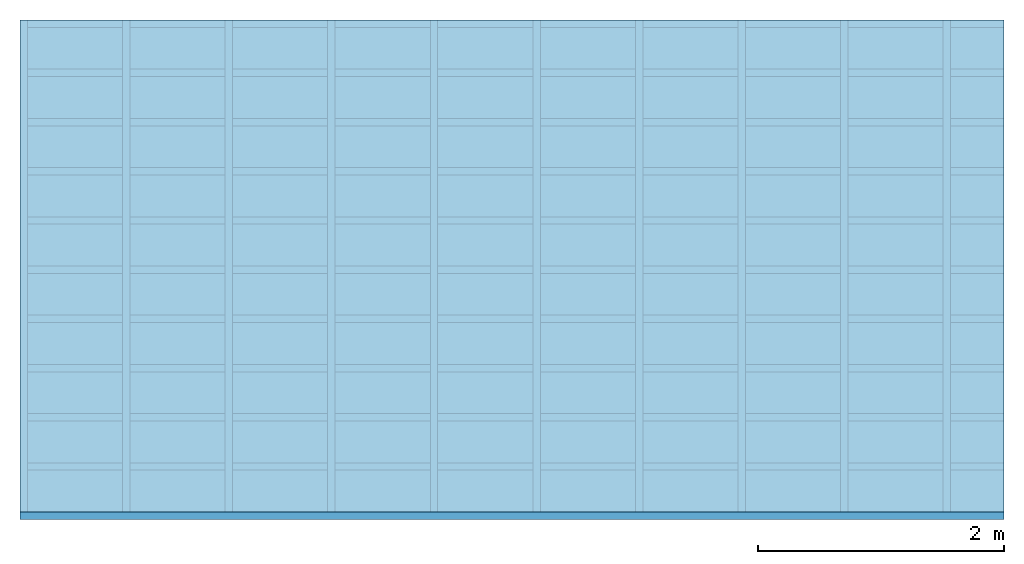
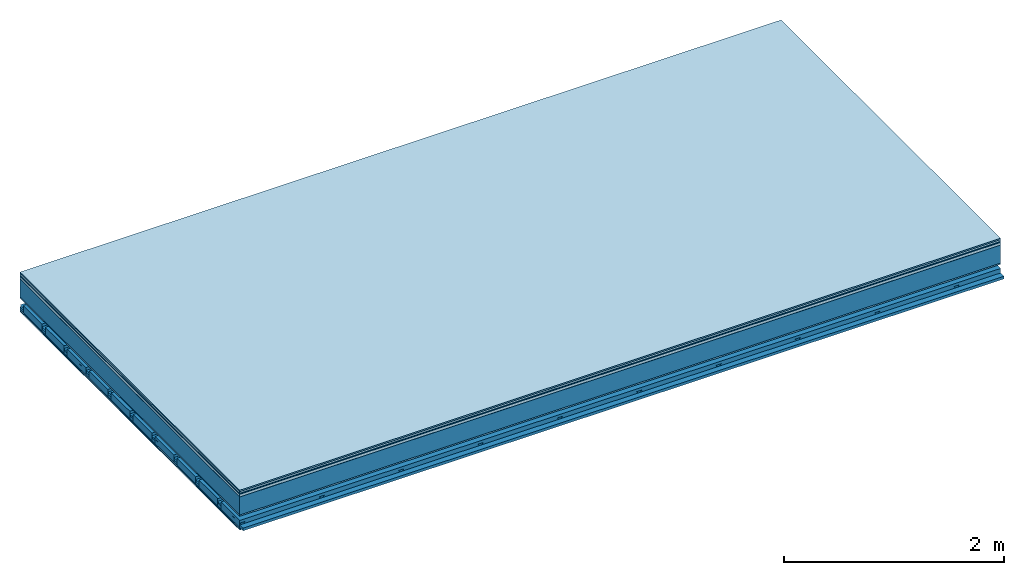
# One storey: 9 plates, 4 members, 1 element without a shape of its own.
"""IFC4 building model written with IfcOpenShell, lengths in metres."""

from ifc_helpers import new_model, si_unit, derived_unit, direction, frame, frame_2d, origin, origin_with_axes, place, context, project, spatial, polyline, rectangle, outline, extrude, material, layer, layer_set, type_object, element, aggregate, save


model = new_model("IFC4")

# Units and contexts
plan_context = context("Plan", 3, precision=1e-05, world=origin(), true_north=direction((0.0, 1.0)))
model_context = context("Model", 3, precision=1e-05, world=origin(), true_north=direction((0.0, 1.0)))
ifc_project = project(units=[si_unit("LENGTHUNIT", "METRE"), derived_unit("SOUNDPRESSUREUNIT", [(si_unit("PRESSUREUNIT", "PASCAL", prefix="MICRO"), 0)]), si_unit("ENERGYUNIT", "JOULE", prefix="MEGA"), si_unit("MASSUNIT", "GRAM", prefix="KILO"), derived_unit("THERMALTRANSMITTANCEUNIT", [(si_unit("POWERUNIT", "WATT"), 1), (si_unit("AREAUNIT", "SQUARE_METRE"), -1), (si_unit("THERMODYNAMICTEMPERATUREUNIT", "KELVIN"), -1)]), derived_unit("AREADENSITYUNIT", [(si_unit("MASSUNIT", "GRAM", prefix="KILO"), 1), (si_unit("AREAUNIT", "SQUARE_METRE"), -1)]), derived_unit("USERDEFINED", [(si_unit("ENERGYUNIT", "JOULE", prefix="MEGA"), 1), (si_unit("AREAUNIT", "SQUARE_METRE"), -1)])], contexts=[plan_context, model_context])

# Site, building, storey
site = spatial("IfcSite", under=ifc_project)
building_placement = place(None, origin())
building = spatial("IfcBuilding", under=site, at=building_placement)
storey_placement = place(building_placement, origin())
storey = spatial("IfcBuildingStorey", under=building, at=storey_placement)

# Slab, members, plates
ifc_material_1 = material(Category="11.013")
ifc_layer_1 = layer(ifc_material_1, 0.015, Name="Flooring")
ifc_material_2 = material(Category="03.007")
ifc_layer_2 = layer(ifc_material_2, 0.02, Name="On-material")
ifc_material_3 = material(Name="Wood fiber generic product", Category="10.009")
ifc_layer_3 = layer(ifc_material_3, 0.01, Name="Impact sound insulation")
ifc_material_4 = material(Name="with broken")
ifc_layer_4 = layer(ifc_material_4, 0.03, Name="on Supporting structure")
ifc_material_5 = material(Name="protection", Category="09.007")
ifc_layer_5 = layer(ifc_material_5, 0.0005, Name="Sub-floor")
ifc_material_6 = material(Name="no composite action")
ifc_layer_6 = layer(ifc_material_6, 0.0, Name="Bond")
ifc_layer_7 = layer(None, 0.2, Name="Supporting structure")
ifc_material_7 = material(Name="of the art")
ifc_layer_8 = layer(ifc_material_7, 0.0, Name="Bond")
ifc_layer_9 = layer(ifc_material_2, 0.015, Name="Lower layer 1")
ifc_layer_10 = layer(None, 0.095, Name="Coupling")
ifc_layer_11 = layer(None, 0.03, Name="Battens / profiles")
ifc_material_8 = material(Name="Plasterboard type A", Category="03.008")
ifc_layer_12 = layer(ifc_material_8, 0.0125, Name="Ceiling covering 1st layer")
ifc_layer_13 = layer(ifc_material_8, 0.0125, Name="Ceiling covering layer 2")
ifc_material_9 = material(Category="04.001")
ifc_layer_14 = layer(ifc_material_9, 0.003, Name="Surface / treatment")
ifc_layer_set = layer_set([ifc_layer_1, ifc_layer_2, ifc_layer_3, ifc_layer_4, ifc_layer_5, ifc_layer_6, ifc_layer_7, ifc_layer_8, ifc_layer_9, ifc_layer_10, ifc_layer_11, ifc_layer_12, ifc_layer_13, ifc_layer_14])
slab_type = type_object("IfcSlabType", Name="A2127", PredefinedType="NOTDEFINED", material=ifc_layer_set)
slab_placement = place(None, frame((0.0, 0.0, 0.0), z_axis=(0.0, 0.0, -1.0), x_axis=(1.0, 0.0, 0.0)))
slab = element("IfcSlab", 1, at=slab_placement, inside=storey, type_object=slab_type, material=ifc_layer_set, Name="Slab #1")
ifc_material_10 = material(Name="Solid timber panel")
member_1_placement = place(slab_placement, origin())
member_1 = element("IfcMember", 2, at=member_1_placement, material=ifc_material_10, Name="Supporting structure", context=plan_context, shape_type="SweptSolid", body=[
    extrude(rectangle(XDim=1.0, YDim=0.2, at=frame_2d((0.5, 0.1), x_axis=(1.0, 0.0))), frame((0.0, 4.0, 0.0755), z_axis=(0.0, -1.0, 0.0), x_axis=(1.0, 0.0, 0.0)), (0.0, 0.0, 1.0), 4.0),
    extrude(rectangle(XDim=1.0, YDim=0.2, at=frame_2d((0.5, 0.1), x_axis=(1.0, 0.0))), frame((1.0, 4.0, 0.0755), z_axis=(0.0, -1.0, 0.0), x_axis=(1.0, 0.0, 0.0)), (0.0, 0.0, 1.0), 4.0),
    extrude(rectangle(XDim=1.0, YDim=0.2, at=frame_2d((0.5, 0.1), x_axis=(1.0, 0.0))), frame((2.0, 4.0, 0.0755), z_axis=(0.0, -1.0, 0.0), x_axis=(1.0, 0.0, 0.0)), (0.0, 0.0, 1.0), 4.0),
    extrude(rectangle(XDim=1.0, YDim=0.2, at=frame_2d((0.5, 0.1), x_axis=(1.0, 0.0))), frame((3.0, 4.0, 0.0755), z_axis=(0.0, -1.0, 0.0), x_axis=(1.0, 0.0, 0.0)), (0.0, 0.0, 1.0), 4.0),
    extrude(rectangle(XDim=1.0, YDim=0.2, at=frame_2d((0.5, 0.1), x_axis=(1.0, 0.0))), frame((4.0, 4.0, 0.0755), z_axis=(0.0, -1.0, 0.0), x_axis=(1.0, 0.0, 0.0)), (0.0, 0.0, 1.0), 4.0),
    extrude(rectangle(XDim=1.0, YDim=0.2, at=frame_2d((0.5, 0.1), x_axis=(1.0, 0.0))), frame((5.0, 4.0, 0.0755), z_axis=(0.0, -1.0, 0.0), x_axis=(1.0, 0.0, 0.0)), (0.0, 0.0, 1.0), 4.0),
    extrude(rectangle(XDim=1.0, YDim=0.2, at=frame_2d((0.5, 0.1), x_axis=(1.0, 0.0))), frame((6.0, 4.0, 0.0755), z_axis=(0.0, -1.0, 0.0), x_axis=(1.0, 0.0, 0.0)), (0.0, 0.0, 1.0), 4.0),
    extrude(rectangle(XDim=1.0, YDim=0.2, at=frame_2d((0.5, 0.1), x_axis=(1.0, 0.0))), frame((7.0, 4.0, 0.0755), z_axis=(0.0, -1.0, 0.0), x_axis=(1.0, 0.0, 0.0)), (0.0, 0.0, 1.0), 4.0),
])
ifc_material_11 = material()
member_2_placement = place(slab_placement, origin())
member_2 = element("IfcMember", 3, at=member_2_placement, material=ifc_material_11, Name="Coupling", context=plan_context, shape_type="SweptSolid", body=[
    extrude(outline(polyline([(0.0, 0.0), (0.06, 0.0), (0.04, 0.02), (0.02, 0.02), (0.0, 0.0)])), frame((0.0, 4.0, 0.3655), z_axis=(0.0, -1.0, 0.0), x_axis=(1.0, 0.0, 0.0)), (0.0, 0.0, 1.0), 4.0),
    extrude(outline(polyline([(0.0, 0.0), (0.06, 0.0), (0.04, 0.02), (0.02, 0.02), (0.0, 0.0)])), frame((0.834, 4.0, 0.3655), z_axis=(0.0, -1.0, 0.0), x_axis=(1.0, 0.0, 0.0)), (0.0, 0.0, 1.0), 4.0),
    extrude(outline(polyline([(0.0, 0.0), (0.06, 0.0), (0.04, 0.02), (0.02, 0.02), (0.0, 0.0)])), frame((1.668, 4.0, 0.3655), z_axis=(0.0, -1.0, 0.0), x_axis=(1.0, 0.0, 0.0)), (0.0, 0.0, 1.0), 4.0),
    extrude(outline(polyline([(0.0, 0.0), (0.06, 0.0), (0.04, 0.02), (0.02, 0.02), (0.0, 0.0)])), frame((2.502, 4.0, 0.3655), z_axis=(0.0, -1.0, 0.0), x_axis=(1.0, 0.0, 0.0)), (0.0, 0.0, 1.0), 4.0),
    extrude(outline(polyline([(0.0, 0.0), (0.06, 0.0), (0.04, 0.02), (0.02, 0.02), (0.0, 0.0)])), frame((3.336, 4.0, 0.3655), z_axis=(0.0, -1.0, 0.0), x_axis=(1.0, 0.0, 0.0)), (0.0, 0.0, 1.0), 4.0),
    extrude(outline(polyline([(0.0, 0.0), (0.06, 0.0), (0.04, 0.02), (0.02, 0.02), (0.0, 0.0)])), frame((4.17, 4.0, 0.3655), z_axis=(0.0, -1.0, 0.0), x_axis=(1.0, 0.0, 0.0)), (0.0, 0.0, 1.0), 4.0),
    extrude(outline(polyline([(0.0, 0.0), (0.06, 0.0), (0.04, 0.02), (0.02, 0.02), (0.0, 0.0)])), frame((5.004, 4.0, 0.3655), z_axis=(0.0, -1.0, 0.0), x_axis=(1.0, 0.0, 0.0)), (0.0, 0.0, 1.0), 4.0),
    extrude(outline(polyline([(0.0, 0.0), (0.06, 0.0), (0.04, 0.02), (0.02, 0.02), (0.0, 0.0)])), frame((5.838, 4.0, 0.3655), z_axis=(0.0, -1.0, 0.0), x_axis=(1.0, 0.0, 0.0)), (0.0, 0.0, 1.0), 4.0),
    extrude(outline(polyline([(0.0, 0.0), (0.06, 0.0), (0.04, 0.02), (0.02, 0.02), (0.0, 0.0)])), frame((6.672, 4.0, 0.3655), z_axis=(0.0, -1.0, 0.0), x_axis=(1.0, 0.0, 0.0)), (0.0, 0.0, 1.0), 4.0),
    extrude(outline(polyline([(0.0, 0.0), (0.06, 0.0), (0.04, 0.02), (0.02, 0.02), (0.0, 0.0)])), frame((7.506, 4.0, 0.3655), z_axis=(0.0, -1.0, 0.0), x_axis=(1.0, 0.0, 0.0)), (0.0, 0.0, 1.0), 4.0),
])
member_3_placement = place(slab_placement, origin())
member_3 = element("IfcMember", 4, at=member_3_placement, material=ifc_material_11, Name="Battens / profiles", context=plan_context, shape_type="SweptSolid", body=[
    extrude(rectangle(XDim=0.06, YDim=0.03, at=frame_2d((0.03, 0.015), x_axis=(1.0, 0.0))), frame((0.0, 0.0, 0.3855), z_axis=(1.0, 0.0, 0.0), x_axis=(0.0, 1.0, 0.0)), (0.0, 0.0, 1.0), 8.0),
    extrude(rectangle(XDim=0.06, YDim=0.03, at=frame_2d((0.03, 0.015), x_axis=(1.0, 0.0))), frame((0.0, 0.4, 0.3855), z_axis=(1.0, 0.0, 0.0), x_axis=(0.0, 1.0, 0.0)), (0.0, 0.0, 1.0), 8.0),
    extrude(rectangle(XDim=0.06, YDim=0.03, at=frame_2d((0.03, 0.015), x_axis=(1.0, 0.0))), frame((0.0, 0.8, 0.3855), z_axis=(1.0, 0.0, 0.0), x_axis=(0.0, 1.0, 0.0)), (0.0, 0.0, 1.0), 8.0),
    extrude(rectangle(XDim=0.06, YDim=0.03, at=frame_2d((0.03, 0.015), x_axis=(1.0, 0.0))), frame((0.0, 1.2, 0.3855), z_axis=(1.0, 0.0, 0.0), x_axis=(0.0, 1.0, 0.0)), (0.0, 0.0, 1.0), 8.0),
    extrude(rectangle(XDim=0.06, YDim=0.03, at=frame_2d((0.03, 0.015), x_axis=(1.0, 0.0))), frame((0.0, 1.6, 0.3855), z_axis=(1.0, 0.0, 0.0), x_axis=(0.0, 1.0, 0.0)), (0.0, 0.0, 1.0), 8.0),
    extrude(rectangle(XDim=0.06, YDim=0.03, at=frame_2d((0.03, 0.015), x_axis=(1.0, 0.0))), frame((0.0, 2.0, 0.3855), z_axis=(1.0, 0.0, 0.0), x_axis=(0.0, 1.0, 0.0)), (0.0, 0.0, 1.0), 8.0),
    extrude(rectangle(XDim=0.06, YDim=0.03, at=frame_2d((0.03, 0.015), x_axis=(1.0, 0.0))), frame((0.0, 2.4, 0.3855), z_axis=(1.0, 0.0, 0.0), x_axis=(0.0, 1.0, 0.0)), (0.0, 0.0, 1.0), 8.0),
    extrude(rectangle(XDim=0.06, YDim=0.03, at=frame_2d((0.03, 0.015), x_axis=(1.0, 0.0))), frame((0.0, 2.8, 0.3855), z_axis=(1.0, 0.0, 0.0), x_axis=(0.0, 1.0, 0.0)), (0.0, 0.0, 1.0), 8.0),
    extrude(rectangle(XDim=0.06, YDim=0.03, at=frame_2d((0.03, 0.015), x_axis=(1.0, 0.0))), frame((0.0, 3.2, 0.3855), z_axis=(1.0, 0.0, 0.0), x_axis=(0.0, 1.0, 0.0)), (0.0, 0.0, 1.0), 8.0),
    extrude(rectangle(XDim=0.06, YDim=0.03, at=frame_2d((0.03, 0.015), x_axis=(1.0, 0.0))), frame((0.0, 3.6, 0.3855), z_axis=(1.0, 0.0, 0.0), x_axis=(0.0, 1.0, 0.0)), (0.0, 0.0, 1.0), 8.0),
    extrude(rectangle(XDim=0.06, YDim=0.03, at=frame_2d((0.03, 0.015), x_axis=(1.0, 0.0))), frame((0.0, 4.0, 0.3855), z_axis=(1.0, 0.0, 0.0), x_axis=(0.0, 1.0, 0.0)), (0.0, 0.0, 1.0), 8.0),
])
ifc_material_12 = material()
member_4_placement = place(slab_placement, origin())
member_4 = element("IfcMember", 5, at=member_4_placement, material=ifc_material_12, Name="Cavity", context=plan_context, shape_type="SweptSolid", body=[
    extrude(rectangle(XDim=0.34, YDim=0.08, at=frame_2d((0.17, 0.04), x_axis=(1.0, 0.0))), frame((0.0, 0.06, 0.3355), z_axis=(1.0, 0.0, 0.0), x_axis=(0.0, 1.0, 0.0)), (0.0, 0.0, 1.0), 8.0),
    extrude(rectangle(XDim=0.34, YDim=0.08, at=frame_2d((0.17, 0.04), x_axis=(1.0, 0.0))), frame((0.0, 0.46, 0.3355), z_axis=(1.0, 0.0, 0.0), x_axis=(0.0, 1.0, 0.0)), (0.0, 0.0, 1.0), 8.0),
    extrude(rectangle(XDim=0.34, YDim=0.08, at=frame_2d((0.17, 0.04), x_axis=(1.0, 0.0))), frame((0.0, 0.86, 0.3355), z_axis=(1.0, 0.0, 0.0), x_axis=(0.0, 1.0, 0.0)), (0.0, 0.0, 1.0), 8.0),
    extrude(rectangle(XDim=0.34, YDim=0.08, at=frame_2d((0.17, 0.04), x_axis=(1.0, 0.0))), frame((0.0, 1.26, 0.3355), z_axis=(1.0, 0.0, 0.0), x_axis=(0.0, 1.0, 0.0)), (0.0, 0.0, 1.0), 8.0),
    extrude(rectangle(XDim=0.34, YDim=0.08, at=frame_2d((0.17, 0.04), x_axis=(1.0, 0.0))), frame((0.0, 1.66, 0.3355), z_axis=(1.0, 0.0, 0.0), x_axis=(0.0, 1.0, 0.0)), (0.0, 0.0, 1.0), 8.0),
    extrude(rectangle(XDim=0.34, YDim=0.08, at=frame_2d((0.17, 0.04), x_axis=(1.0, 0.0))), frame((0.0, 2.06, 0.3355), z_axis=(1.0, 0.0, 0.0), x_axis=(0.0, 1.0, 0.0)), (0.0, 0.0, 1.0), 8.0),
    extrude(rectangle(XDim=0.34, YDim=0.08, at=frame_2d((0.17, 0.04), x_axis=(1.0, 0.0))), frame((0.0, 2.46, 0.3355), z_axis=(1.0, 0.0, 0.0), x_axis=(0.0, 1.0, 0.0)), (0.0, 0.0, 1.0), 8.0),
    extrude(rectangle(XDim=0.34, YDim=0.08, at=frame_2d((0.17, 0.04), x_axis=(1.0, 0.0))), frame((0.0, 2.86, 0.3355), z_axis=(1.0, 0.0, 0.0), x_axis=(0.0, 1.0, 0.0)), (0.0, 0.0, 1.0), 8.0),
    extrude(rectangle(XDim=0.34, YDim=0.08, at=frame_2d((0.17, 0.04), x_axis=(1.0, 0.0))), frame((0.0, 3.26, 0.3355), z_axis=(1.0, 0.0, 0.0), x_axis=(0.0, 1.0, 0.0)), (0.0, 0.0, 1.0), 8.0),
    extrude(rectangle(XDim=0.34, YDim=0.08, at=frame_2d((0.17, 0.04), x_axis=(1.0, 0.0))), frame((0.0, 3.66, 0.3355), z_axis=(1.0, 0.0, 0.0), x_axis=(0.0, 1.0, 0.0)), (0.0, 0.0, 1.0), 8.0),
])
plate_1_placement = place(slab_placement, origin())
plate_1 = element("IfcPlate", 6, at=plate_1_placement, material=ifc_material_1, Name="Flooring", context=plan_context, shape_type="SweptSolid", body=[
    extrude(rectangle(XDim=8.0, YDim=4.0, at=frame_2d((4.0, 2.0), x_axis=(1.0, 0.0))), origin_with_axes(), (0.0, 0.0, 1.0), 0.015),
])
plate_2_placement = place(slab_placement, origin())
plate_2 = element("IfcPlate", 7, at=plate_2_placement, material=ifc_material_2, Name="On-material", context=plan_context, shape_type="SweptSolid", body=[
    extrude(rectangle(XDim=8.0, YDim=4.0, at=frame_2d((4.0, 2.0), x_axis=(1.0, 0.0))), frame((0.0, 0.0, 0.015), z_axis=(0.0, 0.0, 1.0), x_axis=(1.0, 0.0, 0.0)), (0.0, 0.0, 1.0), 0.02),
])
plate_3_placement = place(slab_placement, origin())
plate_3 = element("IfcPlate", 8, at=plate_3_placement, material=ifc_material_3, Name="Impact sound insulation", context=plan_context, shape_type="SweptSolid", body=[
    extrude(rectangle(XDim=8.0, YDim=4.0, at=frame_2d((4.0, 2.0), x_axis=(1.0, 0.0))), frame((0.0, 0.0, 0.035), z_axis=(0.0, 0.0, 1.0), x_axis=(1.0, 0.0, 0.0)), (0.0, 0.0, 1.0), 0.01),
])
plate_4_placement = place(slab_placement, origin())
plate_4 = element("IfcPlate", 9, at=plate_4_placement, material=ifc_material_4, Name="on Supporting structure", context=plan_context, shape_type="SweptSolid", body=[
    extrude(rectangle(XDim=8.0, YDim=4.0, at=frame_2d((4.0, 2.0), x_axis=(1.0, 0.0))), frame((0.0, 0.0, 0.045), z_axis=(0.0, 0.0, 1.0), x_axis=(1.0, 0.0, 0.0)), (0.0, 0.0, 1.0), 0.03),
])
plate_5_placement = place(slab_placement, origin())
plate_5 = element("IfcPlate", 10, at=plate_5_placement, material=ifc_material_5, Name="Sub-floor", context=plan_context, shape_type="SweptSolid", body=[
    extrude(rectangle(XDim=8.0, YDim=4.0, at=frame_2d((4.0, 2.0), x_axis=(1.0, 0.0))), frame((0.0, 0.0, 0.075), z_axis=(0.0, 0.0, 1.0), x_axis=(1.0, 0.0, 0.0)), (0.0, 0.0, 1.0), 0.0005),
])
plate_6_placement = place(slab_placement, origin())
plate_6 = element("IfcPlate", 11, at=plate_6_placement, material=ifc_material_2, Name="Lower layer 1", context=plan_context, shape_type="SweptSolid", body=[
    extrude(rectangle(XDim=8.0, YDim=4.0, at=frame_2d((4.0, 2.0), x_axis=(1.0, 0.0))), frame((0.0, 0.0, 0.2755), z_axis=(0.0, 0.0, 1.0), x_axis=(1.0, 0.0, 0.0)), (0.0, 0.0, 1.0), 0.015),
])
plate_7_placement = place(slab_placement, origin())
plate_7 = element("IfcPlate", 12, at=plate_7_placement, material=ifc_material_8, Name="Ceiling covering 1st layer", context=plan_context, shape_type="SweptSolid", body=[
    extrude(rectangle(XDim=8.0, YDim=4.0, at=frame_2d((4.0, 2.0), x_axis=(1.0, 0.0))), frame((0.0, 0.0, 0.4155), z_axis=(0.0, 0.0, 1.0), x_axis=(1.0, 0.0, 0.0)), (0.0, 0.0, 1.0), 0.0125),
])
plate_8_placement = place(slab_placement, origin())
plate_8 = element("IfcPlate", 13, at=plate_8_placement, material=ifc_material_8, Name="Ceiling covering layer 2", context=plan_context, shape_type="SweptSolid", body=[
    extrude(rectangle(XDim=8.0, YDim=4.0, at=frame_2d((4.0, 2.0), x_axis=(1.0, 0.0))), frame((0.0, 0.0, 0.428), z_axis=(0.0, 0.0, 1.0), x_axis=(1.0, 0.0, 0.0)), (0.0, 0.0, 1.0), 0.0125),
])
plate_9_placement = place(slab_placement, origin())
plate_9 = element("IfcPlate", 14, at=plate_9_placement, material=ifc_material_9, Name="Surface / treatment", context=plan_context, shape_type="SweptSolid", body=[
    extrude(rectangle(XDim=8.0, YDim=4.0, at=frame_2d((4.0, 2.0), x_axis=(1.0, 0.0))), frame((0.0, 0.0, 0.4405), z_axis=(0.0, 0.0, 1.0), x_axis=(1.0, 0.0, 0.0)), (0.0, 0.0, 1.0), 0.003),
])
aggregate(slab, [plate_1, plate_2, plate_3, plate_4, plate_5, member_1, plate_6, member_2, member_3, member_4, plate_7, plate_8, plate_9])

save(model, "model.ifc")
